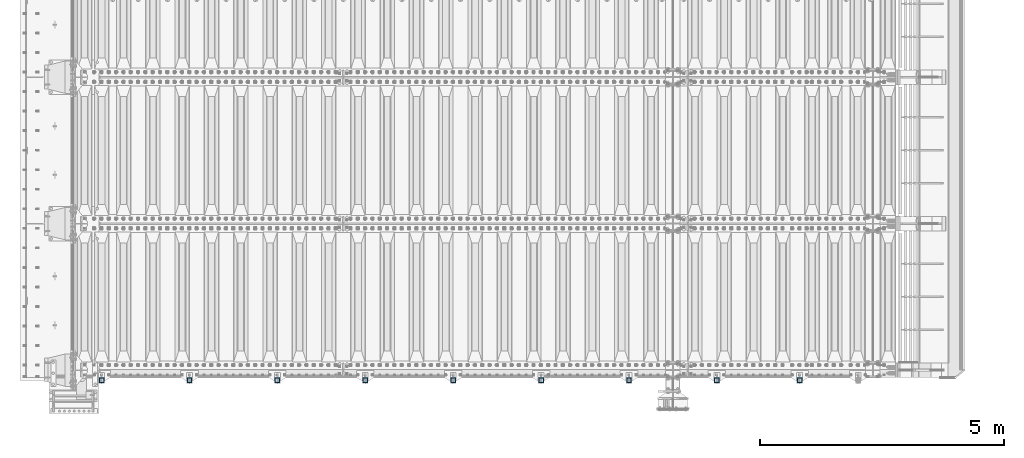
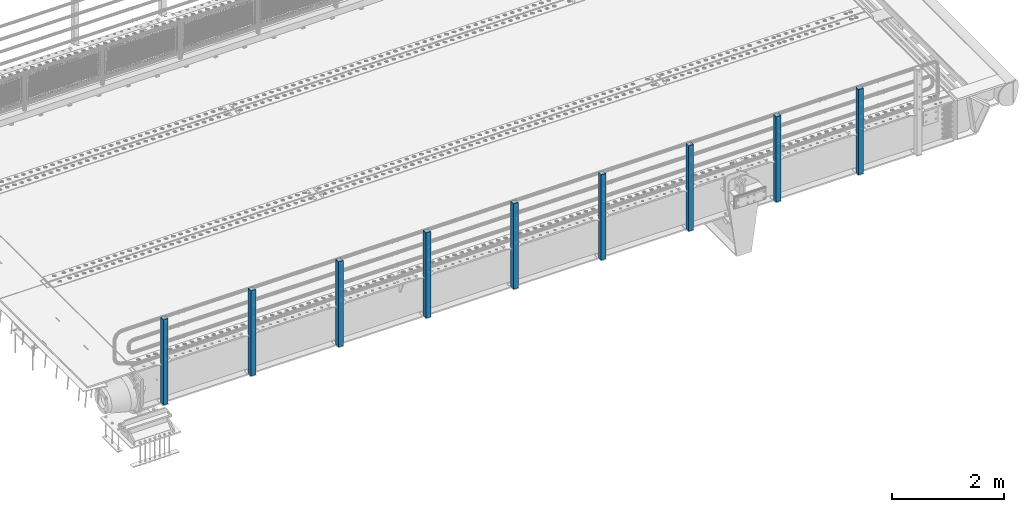
# One storey, part 62 of 247: 9 columns.
"""IFC2X3 building model written with IfcOpenShell, lengths in millimetres."""

from ifc_helpers import new_model, si_unit, frame, origin_with_axes, place, context, subcontext, project, spatial, faceted_brep, material, type_object, element, save


model = new_model("IFC2X3")

# Units and contexts
model_context = context("Model", 3, precision=1e-05, world=origin_with_axes())
body_context = subcontext(model_context, "Body", "Model", "MODEL_VIEW")
ifc_project = project(units=[si_unit("LENGTHUNIT", "METRE", prefix="MILLI"), si_unit("AREAUNIT", "SQUARE_METRE"), si_unit("VOLUMEUNIT", "CUBIC_METRE"), si_unit("MASSUNIT", "GRAM", prefix="KILO"), si_unit("TIMEUNIT", "SECOND"), si_unit("PLANEANGLEUNIT", "RADIAN"), si_unit("SOLIDANGLEUNIT", "STERADIAN"), si_unit("THERMODYNAMICTEMPERATUREUNIT", "DEGREE_CELSIUS"), si_unit("LUMINOUSINTENSITYUNIT", "LUMEN")], contexts=[model_context])

# Site, building, storey
site_placement = place(None, origin_with_axes())
site = spatial("IfcSite", under=ifc_project, at=site_placement, CompositionType="ELEMENT")
building_placement = place(site_placement, origin_with_axes())
building = spatial("IfcBuilding", under=site, at=building_placement, Name="Standard", CompositionType="ELEMENT")
storey_placement = place(building_placement, origin_with_axes())
storey = spatial("IfcBuildingStorey", under=building, at=storey_placement, Name="Undefined", CompositionType="ELEMENT", Elevation=0.0)

# Columns
ifc_material = material()
column_type = type_object("IfcColumnType", PredefinedType="NOTDEFINED")
for number, where, z_axis, x_axis in (
    (1, (14844.9999999999, -210.000000000206, -844.999999999998), (0.0, 1.0, 0.0), (0.0, 0.0, 1.0)),
    (2, (13149.9999999999, -210.000000000206, -844.999999999998), (0.0, 1.0, 0.0), (0.0, 0.0, 1.0)),
    (3, (11349.9999999999, -210.000000000206, -844.999999999998), (0.0, 1.0, 0.0), (0.0, 0.0, 1.0)),
    (4, (9549.99999999987, -210.000000000206, -844.999999999998), (0.0, 1.0, 0.0), (0.0, 0.0, 1.0)),
    (5, (7749.99999999987, -210.000000000206, -844.999999999998), (0.0, 1.0, 0.0), (0.0, 0.0, 1.0)),
    (6, (5949.99999999987, -210.000000000206, -844.999999999998), (0.0, 1.0, 0.0), (0.0, 0.0, 1.0)),
    (7, (4149.99999999987, -210.000000000206, -844.999999999998), (0.0, 1.0, 0.0), (0.0, 0.0, 1.0)),
    (8, (2349.99999999987, -210.000000000206, -844.999999999998), (0.0, 1.0, 0.0), (0.0, 0.0, 1.0)),
    (9, (549.999999999869, -210.000000000206, -844.999999999998), (0.0, 1.0, 0.0), (0.0, 0.0, 1.0)),
):
    element("IfcColumn", number, at=place(storey_placement, frame(where, z_axis=z_axis, x_axis=x_axis)), inside=storey, type_object=column_type, material=ifc_material, context=body_context, shape_type="Brep", body=[
        faceted_brep([(0.0, 40.0, -40.0), (0.0, -40.0, -40.0), (1855.0, -40.0, -40.0), (1855.0, 40.0, -40.0), (0.0, -40.0, 40.0), (1855.0, -40.0, 40.0), (0.0, 40.0, 40.0), (1855.0, 40.0, 40.0), (0.0, 50.0, -50.0), (0.0, 50.0, 50.0), (1855.0, 50.0, 50.0), (1855.0, 50.0, -50.0), (0.0, -50.0, 50.0), (1855.0, -50.0, 50.0), (0.0, -50.0, -50.0), (1855.0, -50.0, -50.0)], [[[0, 1, 2, 3]], [[1, 4, 5, 2]], [[4, 6, 7, 5]], [[6, 0, 3, 7]], [[8, 9, 10, 11]], [[9, 12, 13, 10]], [[12, 14, 15, 13]], [[14, 8, 11, 15]], [[13, 15, 11, 10], [5, 7, 3, 2]], [[14, 12, 9, 8], [6, 4, 1, 0]]]),
    ])

save(model, "model.ifc")
